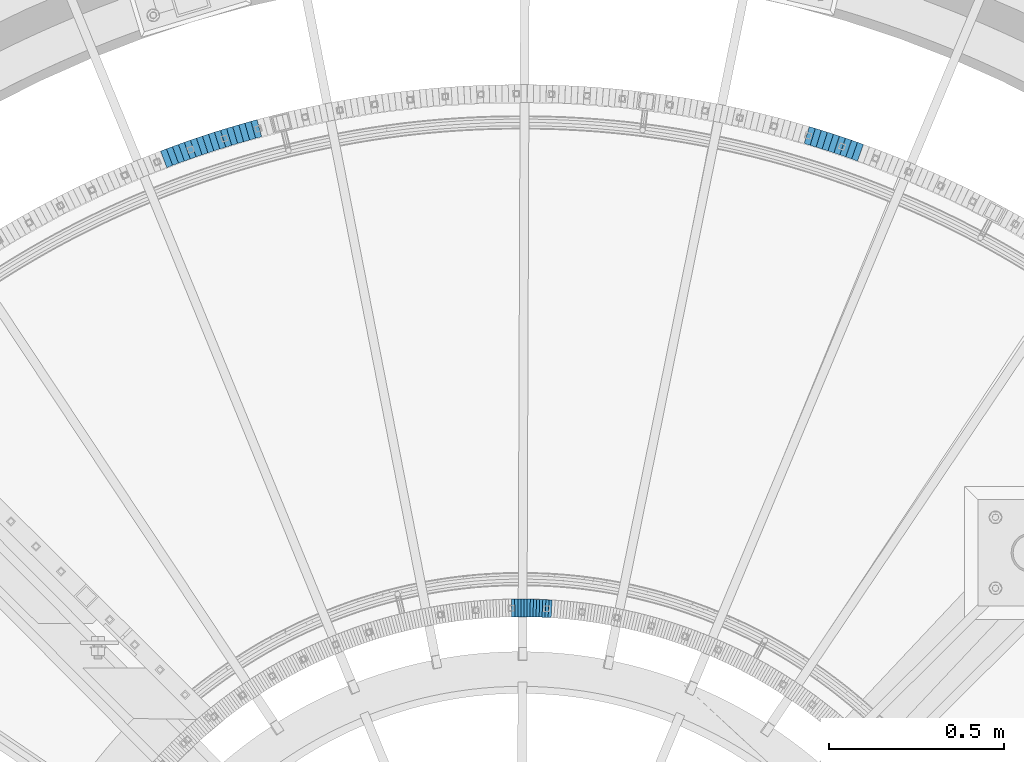
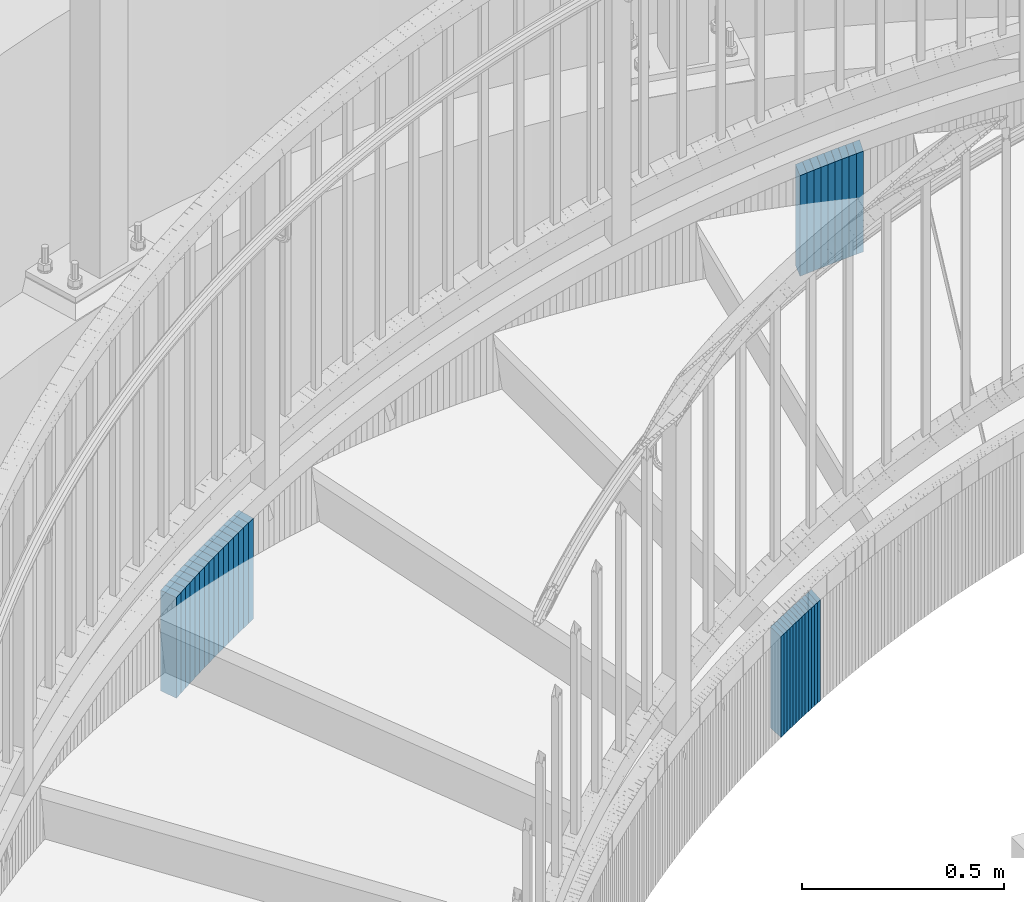
# One storey, part 902 of 975: 38 plates.
"""IFC2X3 building model written with IfcOpenShell, lengths in millimetres."""

from ifc_helpers import new_model, si_unit, frame, origin_with_axes, place, context, subcontext, project, spatial, faceted_brep, material, type_object, element, save


model = new_model("IFC2X3")

# Units and contexts
model_context = context("Model", 3, precision=1e-05, world=origin_with_axes())
body_context = subcontext(model_context, "Body", "Model", "MODEL_VIEW")
ifc_project = project(units=[si_unit("LENGTHUNIT", "METRE", prefix="MILLI"), si_unit("AREAUNIT", "SQUARE_METRE"), si_unit("VOLUMEUNIT", "CUBIC_METRE"), si_unit("MASSUNIT", "GRAM", prefix="KILO"), si_unit("TIMEUNIT", "SECOND"), si_unit("PLANEANGLEUNIT", "RADIAN"), si_unit("SOLIDANGLEUNIT", "STERADIAN"), si_unit("THERMODYNAMICTEMPERATUREUNIT", "DEGREE_CELSIUS"), si_unit("LUMINOUSINTENSITYUNIT", "LUMEN")], contexts=[model_context])

# Site, building, storey
site_placement = place(None, origin_with_axes())
site = spatial("IfcSite", under=ifc_project, at=site_placement, CompositionType="ELEMENT")
building_placement = place(site_placement, origin_with_axes())
building = spatial("IfcBuilding", under=site, at=building_placement, Name="Undefined", CompositionType="ELEMENT")
storey_placement = place(building_placement, origin_with_axes())
storey = spatial("IfcBuildingStorey", under=building, at=storey_placement, Name="Undefined", CompositionType="ELEMENT", Elevation=0.0)

# Plates
ifc_material = material(Name="STEEL/A36")
plate_type_1 = type_object("IfcPlateType", PredefinedType="NOTDEFINED")
plate_1_placement = place(storey_placement, frame((35690.0951937879, 6110.51674939472, 1376.49999999174), z_axis=(0.942371042718134, -0.334569600899929, 0.0), x_axis=(0.0, 0.0, -1.0)))
element("IfcPlate", 1, at=plate_1_placement, inside=storey, type_object=plate_type_1, material=ifc_material, Name="WALL", context=body_context, shape_type="Brep", body=[
    faceted_brep([(0.0, -25.3999999999724, -1.81898940354586e-11), (-5.69999980926514, -25.3999999999942, 17.9287471771386), (-5.69999980926514, 25.3999999999796, 17.9287471770876), (0.0, 25.3999999999869, 1.45519152283669e-11), (299.100006103516, -25.3999999999942, 17.9287471771386), (299.100006103516, 25.3999999999796, 17.9287471770876), (304.799987792969, -25.3999999999724, -1.81898940354586e-11), (304.799987792969, 25.3999999999869, 1.45519152283669e-11)], [[[0, 1, 2, 3]], [[1, 4, 5, 2]], [[4, 6, 7, 5]], [[6, 0, 3, 7]], [[5, 7, 3, 2]], [[6, 4, 1, 0]]]),
])
plate_2_placement = place(storey_placement, frame((35673.340070412, 6116.50076946703, 1370.69999999174), z_axis=(0.941741911475464, -0.336336397332401, 3.18269030685769e-10), x_axis=(0.0, 0.0, -1.0)))
element("IfcPlate", 2, at=plate_2_placement, inside=storey, type_object=plate_type_1, material=ifc_material, Name="WALL", context=body_context, shape_type="Brep", body=[
    faceted_brep([(0.0, -25.3999999999724, -1.81898940354586e-11), (-5.80000019073486, -25.3999999999578, 17.8370399475461), (-5.80000019073486, 25.4000000000524, 17.8370399475607), (0.0, 25.3999999999869, 1.45519152283669e-11), (299.0, -25.3999999999578, 17.8370399475461), (299.0, 25.4000000000524, 17.8370399475607), (304.799987792969, -25.3999999999724, -1.81898940354586e-11), (304.799987792969, 25.3999999999869, 1.45519152283669e-11)], [[[0, 1, 2, 3]], [[1, 4, 5, 2]], [[4, 6, 7, 5]], [[6, 0, 3, 7]], [[5, 7, 3, 2]], [[6, 4, 1, 0]]]),
])
plate_3_placement = place(storey_placement, frame((35656.1422322019, 6122.40505867621, 1364.99999999174), z_axis=(0.945847786021473, -0.324610483007371, 0.0), x_axis=(0.0, 0.0, -1.0)))
element("IfcPlate", 3, at=plate_3_placement, inside=storey, type_object=plate_type_1, material=ifc_material, Name="WALL", context=body_context, shape_type="Brep", body=[
    faceted_brep([(0.0, -25.3999999999724, -1.81898940354586e-11), (-5.69999980926514, -25.4000000000524, 17.8734436034756), (-5.69999980926514, 25.4000000000888, 17.8734436035884), (0.0, 25.3999999999869, 1.45519152283669e-11), (299.100006103516, -25.4000000000524, 17.8734436034756), (299.100006103516, 25.4000000000888, 17.8734436035884), (304.799987792969, -25.3999999999724, -1.81898940354586e-11), (304.799987792969, 25.3999999999869, 1.45519152283669e-11)], [[[0, 1, 2, 3]], [[1, 4, 5, 2]], [[4, 6, 7, 5]], [[6, 0, 3, 7]], [[5, 7, 3, 2]], [[6, 4, 1, 0]]]),
])
plate_4_placement = place(storey_placement, frame((35638.9717969497, 6128.16287711789, 1359.29999999174), z_axis=(0.948124102702791, -0.317900433900346, 0.0), x_axis=(0.0, 0.0, -1.0)))
element("IfcPlate", 4, at=plate_4_placement, inside=storey, type_object=plate_type_1, material=ifc_material, Name="WALL", context=body_context, shape_type="Brep", body=[
    faceted_brep([(0.0, -25.3999999999724, -1.81898940354586e-11), (-5.69999980926514, -25.3999999999942, 17.9287471771386), (-5.69999980926514, 25.3999999999796, 17.9287471770876), (0.0, 25.3999999999869, 1.45519152283669e-11), (299.100006103516, -25.3999999999942, 17.9287471771386), (299.100006103516, 25.3999999999796, 17.9287471770876), (304.799987792969, -25.3999999999724, -1.81898940354586e-11), (304.799987792969, 25.3999999999869, 1.45519152283669e-11)], [[[0, 1, 2, 3]], [[1, 4, 5, 2]], [[4, 6, 7, 5]], [[6, 0, 3, 7]], [[5, 7, 3, 2]], [[6, 4, 1, 0]]]),
])
plate_5_placement = place(storey_placement, frame((35621.857606345, 6133.73363749591, 1353.49999999174), z_axis=(0.950909944301323, -0.309467733098063, 0.0), x_axis=(0.0, 0.0, -1.0)))
element("IfcPlate", 5, at=plate_5_placement, inside=storey, type_object=plate_type_1, material=ifc_material, Name="WALL", context=body_context, shape_type="Brep", body=[
    faceted_brep([(0.0, -25.3999999999724, -1.81898940354586e-11), (-5.80000019073486, -25.400000000016, 17.7730140686072), (-5.80000019073486, 25.4000000000742, 17.7730140686326), (0.0, 25.3999999999869, 1.45519152283669e-11), (299.0, -25.400000000016, 17.7730140686072), (299.0, 25.4000000000742, 17.7730140686326), (304.799987792969, -25.3999999999724, -1.81898940354586e-11), (304.799987792969, 25.3999999999869, 1.45519152283669e-11)], [[[0, 1, 2, 3]], [[1, 4, 5, 2]], [[4, 6, 7, 5]], [[6, 0, 3, 7]], [[5, 7, 3, 2]], [[6, 4, 1, 0]]]),
])
plate_6_placement = place(storey_placement, frame((35604.8157611553, 6139.24721568696, 1347.79999999174), z_axis=(0.951444518718076, -0.30782028490879, 0.0), x_axis=(0.0, 0.0, -1.0)))
element("IfcPlate", 6, at=plate_6_placement, inside=storey, type_object=plate_type_1, material=ifc_material, Name="WALL", context=body_context, shape_type="Brep", body=[
    faceted_brep([(0.0, -25.3999999999724, -1.81898940354586e-11), (-5.69999980926514, -25.4000000000524, 17.8734436034756), (-5.69999980926514, 25.4000000000888, 17.8734436035884), (0.0, 25.3999999999869, 1.45519152283669e-11), (299.100006103516, -25.4000000000524, 17.8734436034756), (299.100006103516, 25.4000000000888, 17.8734436035884), (304.799987792969, -25.3999999999724, -1.81898940354586e-11), (304.799987792969, 25.3999999999869, 1.45519152283669e-11)], [[[0, 1, 2, 3]], [[1, 4, 5, 2]], [[4, 6, 7, 5]], [[6, 0, 3, 7]], [[5, 7, 3, 2]], [[6, 4, 1, 0]]]),
])
plate_7_placement = place(storey_placement, frame((35587.5458626546, 6144.70152460575, 1342.09999999174), z_axis=(0.953582665103915, -0.301131368032814, 0.0), x_axis=(0.0, 0.0, -1.0)))
element("IfcPlate", 7, at=plate_7_placement, inside=storey, type_object=plate_type_1, material=ifc_material, Name="WALL", context=body_context, shape_type="Brep", body=[
    faceted_brep([(0.0, -25.3999999999724, -1.81898940354586e-11), (-5.69999980926514, -25.3999999999942, 17.9287471771386), (-5.69999980926514, 25.3999999999796, 17.9287471770876), (0.0, 25.3999999999869, 1.45519152283669e-11), (299.100006103516, -25.3999999999942, 17.9287471771386), (299.100006103516, 25.3999999999796, 17.9287471770876), (304.799987792969, -25.3999999999724, -1.81898940354586e-11), (304.799987792969, 25.3999999999869, 1.45519152283669e-11)], [[[0, 1, 2, 3]], [[1, 4, 5, 2]], [[4, 6, 7, 5]], [[6, 0, 3, 7]], [[5, 7, 3, 2]], [[6, 4, 1, 0]]]),
])
plate_8_placement = place(storey_placement, frame((35570.3267361922, 6149.96963545787, 1336.39999999174), z_axis=(0.956264194651992, -0.292504341893548, 0.0), x_axis=(0.0, 0.0, -1.0)))
element("IfcPlate", 8, at=plate_8_placement, inside=storey, type_object=plate_type_1, material=ifc_material, Name="WALL", context=body_context, shape_type="Brep", body=[
    faceted_brep([(0.0, -25.3999999999724, -1.81898940354586e-11), (-5.69999980926514, -25.4000000000015, 17.7775135040429), (-5.69999980926514, 25.4000000000251, 17.7775135040793), (0.0, 25.3999999999869, 1.45519152283669e-11), (299.100006103516, -25.4000000000015, 17.7775135040429), (299.100006103516, 25.4000000000251, 17.7775135040793), (304.799987792969, -25.3999999999724, -1.81898940354586e-11), (304.799987792969, 25.3999999999869, 1.45519152283669e-11)], [[[0, 1, 2, 3]], [[1, 4, 5, 2]], [[4, 6, 7, 5]], [[6, 0, 3, 7]], [[5, 7, 3, 2]], [[6, 4, 1, 0]]]),
])
plate_9_placement = place(storey_placement, frame((35553.1869757374, 6155.18176190574, 1330.59999999174), z_axis=(0.956741613892852, -0.290938969967417, 0.0), x_axis=(0.0, 0.0, -1.0)))
element("IfcPlate", 9, at=plate_9_placement, inside=storey, type_object=plate_type_1, material=ifc_material, Name="WALL", context=body_context, shape_type="Brep", body=[
    faceted_brep([(0.0, -25.3999999999724, -1.81898940354586e-11), (-5.80000019073486, -25.4000000000524, 17.8675689696865), (-5.80000019073486, 25.4000000000888, 17.867568969803), (0.0, 25.3999999999869, 1.45519152283669e-11), (299.0, -25.4000000000524, 17.8675689696865), (299.0, 25.4000000000888, 17.867568969803), (304.799987792969, -25.3999999999724, -1.81898940354586e-11), (304.799987792969, 25.3999999999869, 1.45519152283669e-11)], [[[0, 1, 2, 3]], [[1, 4, 5, 2]], [[4, 6, 7, 5]], [[6, 0, 3, 7]], [[5, 7, 3, 2]], [[6, 4, 1, 0]]]),
])
plate_10_placement = place(storey_placement, frame((33968.0018909956, 6170.18223563984, 820.099999991737), z_axis=(0.96463428122535, 0.263591926061578, 0.0), x_axis=(0.0, 0.0, -1.0)))
element("IfcPlate", 10, at=plate_10_placement, inside=storey, type_object=plate_type_1, material=ifc_material, Name="WALL", context=body_context, shape_type="Brep", body=[
    faceted_brep([(0.0, -25.3999999999724, -1.81898940354586e-11), (-5.80000019073486, -25.4000000000078, 17.8305912018768), (-5.80000019073486, 25.4000000000042, 17.8305912017677), (0.0, 25.3999999999869, 1.45519152283669e-11), (299.0, -25.4000000000078, 17.8305912018768), (299.0, 25.4000000000042, 17.8305912017677), (304.799987792969, -25.3999999999724, -1.81898940354586e-11), (304.799987792969, 25.3999999999869, 1.45519152283669e-11)], [[[0, 1, 2, 3]], [[1, 4, 5, 2]], [[4, 6, 7, 5]], [[6, 0, 3, 7]], [[5, 7, 3, 2]], [[6, 4, 1, 0]]]),
])
for number, where, z_axis, x_axis, name in (
    (11, (33950.537969163, 6165.20858534691, 814.399999991737), (0.961734663398033, 0.273982549113392, 0.0), (0.0, 0.0, -1.0), "WALL"),
    (12, (33933.337969156, 6160.30858534617, 808.699999991737), (0.961734663398033, 0.273982549113392, 0.0), (0.0, 0.0, -1.0), "WALL"),
):
    element("IfcPlate", number, at=place(storey_placement, frame(where, z_axis=z_axis, x_axis=x_axis)), inside=storey, type_object=plate_type_1, material=ifc_material, Name=name, context=body_context, shape_type="Brep", body=[
        faceted_brep([(0.0, -25.3999999999724, -1.81898940354586e-11), (-5.69999980926514, -25.4000000000233, 17.8807163238162), (-5.69999980926514, 25.400000000096, 17.8807163239253), (0.0, 25.3999999999869, 1.45519152283669e-11), (299.100006103516, -25.4000000000233, 17.8807163238162), (299.100006103516, 25.400000000096, 17.8807163239253), (304.799987792969, -25.3999999999724, -1.81898940354586e-11), (304.799987792969, 25.3999999999869, 1.45519152283669e-11)], [[[0, 1, 2, 3]], [[1, 4, 5, 2]], [[4, 6, 7, 5]], [[6, 0, 3, 7]], [[5, 7, 3, 2]], [[6, 4, 1, 0]]]),
    ])
plate_11_placement = place(storey_placement, frame((33916.0687036398, 6155.25972906624, 802.999999991737), z_axis=(0.95981118781202, 0.280646545945036, 0.0), x_axis=(0.0, 0.0, -1.0)))
element("IfcPlate", 13, at=plate_11_placement, inside=storey, type_object=plate_type_1, material=ifc_material, Name="WALL", context=body_context, shape_type="Brep", body=[
    faceted_brep([(0.0, -25.3999999999724, -1.81898940354586e-11), (-5.69999980926514, -25.4000000000669, 17.8227386474155), (-5.69999980926514, 25.3999999999724, 17.8227386474609), (0.0, 25.3999999999869, 1.45519152283669e-11), (299.100006103516, -25.4000000000669, 17.8227386474155), (299.100006103516, 25.3999999999724, 17.8227386474609), (304.799987792969, -25.3999999999724, -1.81898940354586e-11), (304.799987792969, 25.3999999999869, 1.45519152283669e-11)], [[[0, 1, 2, 3]], [[1, 4, 5, 2]], [[4, 6, 7, 5]], [[6, 0, 3, 7]], [[5, 7, 3, 2]], [[6, 4, 1, 0]]]),
])
plate_12_placement = place(storey_placement, frame((33898.7072760665, 6149.98176188795, 797.199999991737), z_axis=(0.956741613892852, 0.290938969967417, 0.0), x_axis=(0.0, 0.0, -1.0)))
element("IfcPlate", 14, at=plate_12_placement, inside=storey, type_object=plate_type_1, material=ifc_material, Name="WALL", context=body_context, shape_type="Brep", body=[
    faceted_brep([(0.0, -25.3999999999724, -1.81898940354586e-11), (-5.80000019073486, -25.4000000000524, 17.8675689696865), (-5.80000019073486, 25.4000000000888, 17.867568969803), (0.0, 25.3999999999869, 1.45519152283669e-11), (299.0, -25.4000000000524, 17.8675689696865), (299.0, 25.4000000000888, 17.867568969803), (304.799987792969, -25.3999999999724, -1.81898940354586e-11), (304.799987792969, 25.3999999999869, 1.45519152283669e-11)], [[[0, 1, 2, 3]], [[1, 4, 5, 2]], [[4, 6, 7, 5]], [[6, 0, 3, 7]], [[5, 7, 3, 2]], [[6, 4, 1, 0]]]),
])
plate_13_placement = place(storey_placement, frame((33881.6072760635, 6144.7817618891, 791.499999991737), z_axis=(0.956741613892852, 0.290938969967417, 0.0), x_axis=(0.0, 0.0, -1.0)))
element("IfcPlate", 15, at=plate_13_placement, inside=storey, type_object=plate_type_1, material=ifc_material, Name="WALL", context=body_context, shape_type="Brep", body=[
    faceted_brep([(0.0, -25.3999999999724, -1.81898940354586e-11), (-5.69999980926514, -25.4000000000524, 17.8734436034756), (-5.69999980926514, 25.4000000000888, 17.8734436035884), (0.0, 25.3999999999869, 1.45519152283669e-11), (299.100006103516, -25.4000000000524, 17.8734436034756), (299.100006103516, 25.4000000000888, 17.8734436035884), (304.799987792969, -25.3999999999724, -1.81898940354586e-11), (304.799987792969, 25.3999999999869, 1.45519152283669e-11)], [[[0, 1, 2, 3]], [[1, 4, 5, 2]], [[4, 6, 7, 5]], [[6, 0, 3, 7]], [[5, 7, 3, 2]], [[6, 4, 1, 0]]]),
])
plate_14_placement = place(storey_placement, frame((33864.3075092682, 6139.28857719629, 785.799999991737), z_axis=(0.953072925427516, 0.302740811284235, 5.18711658514804e-10), x_axis=(0.0, 0.0, -1.0)))
element("IfcPlate", 16, at=plate_14_placement, inside=storey, type_object=plate_type_1, material=ifc_material, Name="WALL", context=body_context, shape_type="Brep", body=[
    faceted_brep([(0.0, -25.3999999999724, -1.81898940354586e-11), (-5.69999980926514, -25.3999999999614, 17.8370399475461), (-5.69999980926514, 25.4000000000487, 17.8370399475571), (0.0, 25.3999999999869, 1.45519152283669e-11), (299.100006103516, -25.3999999999614, 17.8370399475461), (299.100006103516, 25.4000000000487, 17.8370399475571), (304.799987792969, -25.3999999999724, -1.81898940354586e-11), (304.799987792969, 25.3999999999869, 1.45519152283669e-11)], [[[0, 1, 2, 3]], [[1, 4, 5, 2]], [[4, 6, 7, 5]], [[6, 0, 3, 7]], [[5, 7, 3, 2]], [[6, 4, 1, 0]]]),
])
plate_15_placement = place(storey_placement, frame((33847.1784906658, 6133.74721567303, 780.099999991737), z_axis=(0.951444518718076, 0.30782028490879, 0.0), x_axis=(0.0, 0.0, -1.0)))
element("IfcPlate", 17, at=plate_15_placement, inside=storey, type_object=plate_type_1, material=ifc_material, Name="WALL", context=body_context, shape_type="Brep", body=[
    faceted_brep([(0.0, -25.3999999999724, -1.81898940354586e-11), (-5.69999980926514, -25.4000000000524, 17.8734436034756), (-5.69999980926514, 25.4000000000888, 17.8734436035884), (0.0, 25.3999999999869, 1.45519152283669e-11), (299.100006103516, -25.4000000000524, 17.8734436034756), (299.100006103516, 25.4000000000888, 17.8734436035884), (304.799987792969, -25.3999999999724, -1.81898940354586e-11), (304.799987792969, 25.3999999999869, 1.45519152283669e-11)], [[[0, 1, 2, 3]], [[1, 4, 5, 2]], [[4, 6, 7, 5]], [[6, 0, 3, 7]], [[5, 7, 3, 2]], [[6, 4, 1, 0]]]),
])
plate_16_placement = place(storey_placement, frame((33830.1784906737, 6128.24721567412, 774.299999991737), z_axis=(0.951444518718076, 0.30782028490879, 0.0), x_axis=(0.0, 0.0, -1.0)))
element("IfcPlate", 18, at=plate_16_placement, inside=storey, type_object=plate_type_1, material=ifc_material, Name="WALL", context=body_context, shape_type="Brep", body=[
    faceted_brep([(0.0, -25.3999999999724, -1.81898940354586e-11), (-5.80000019073486, -25.4000000000524, 17.8675689696865), (-5.80000019073486, 25.4000000000888, 17.867568969803), (0.0, 25.3999999999869, 1.45519152283669e-11), (299.0, -25.4000000000524, 17.8675689696865), (299.0, 25.4000000000888, 17.867568969803), (304.799987792969, -25.3999999999724, -1.81898940354586e-11), (304.799987792969, 25.3999999999869, 1.45519152283669e-11)], [[[0, 1, 2, 3]], [[1, 4, 5, 2]], [[4, 6, 7, 5]], [[6, 0, 3, 7]], [[5, 7, 3, 2]], [[6, 4, 1, 0]]]),
])
plate_17_placement = place(storey_placement, frame((33812.9795429034, 6122.44844641515, 768.599999991737), z_axis=(0.947555965244538, 0.319589882082478, 0.0), x_axis=(0.0, 0.0, -1.0)))
element("IfcPlate", 19, at=plate_17_placement, inside=storey, type_object=plate_type_1, material=ifc_material, Name="WALL", context=body_context, shape_type="Brep", body=[
    faceted_brep([(0.0, -25.3999999999724, -1.81898940354586e-11), (-5.69999980926514, -25.3999999999614, 17.8370399475461), (-5.69999980926514, 25.4000000000487, 17.8370399475571), (0.0, 25.3999999999869, 1.45519152283669e-11), (299.100006103516, -25.3999999999614, 17.8370399475461), (299.100006103516, 25.4000000000487, 17.8370399475571), (304.799987792969, -25.3999999999724, -1.81898940354586e-11), (304.799987792969, 25.3999999999869, 1.45519152283669e-11)], [[[0, 1, 2, 3]], [[1, 4, 5, 2]], [[4, 6, 7, 5]], [[6, 0, 3, 7]], [[5, 7, 3, 2]], [[6, 4, 1, 0]]]),
])
plate_18_placement = place(storey_placement, frame((33795.9520196408, 6116.60505866201, 762.899999991737), z_axis=(0.945847786021473, 0.324610483007371, 0.0), x_axis=(0.0, 0.0, -1.0)))
element("IfcPlate", 20, at=plate_18_placement, inside=storey, type_object=plate_type_1, material=ifc_material, Name="WALL", context=body_context, shape_type="Brep", body=[
    faceted_brep([(0.0, -25.3999999999724, -1.81898940354586e-11), (-5.69999980926514, -25.4000000000524, 17.8734436034756), (-5.69999980926514, 25.4000000000888, 17.8734436035884), (0.0, 25.3999999999869, 1.45519152283669e-11), (299.100006103516, -25.4000000000524, 17.8734436034756), (299.100006103516, 25.4000000000888, 17.8734436035884), (304.799987792969, -25.3999999999724, -1.81898940354586e-11), (304.799987792969, 25.3999999999869, 1.45519152283669e-11)], [[[0, 1, 2, 3]], [[1, 4, 5, 2]], [[4, 6, 7, 5]], [[6, 0, 3, 7]], [[5, 7, 3, 2]], [[6, 4, 1, 0]]]),
])
plate_19_placement = place(storey_placement, frame((33778.7990580419, 6110.51674938196, 757.099999991737), z_axis=(0.942371042718134, 0.334569600899929, 0.0), x_axis=(0.0, 0.0, -1.0)))
element("IfcPlate", 21, at=plate_19_placement, inside=storey, type_object=plate_type_1, material=ifc_material, Name="WALL", context=body_context, shape_type="Brep", body=[
    faceted_brep([(0.0, -25.3999999999724, -1.81898940354586e-11), (-5.80000019073486, -25.3999999998778, 17.9254016876821), (-5.80000019073486, 25.3999999999651, 17.9254016876057), (0.0, 25.3999999999869, 1.45519152283669e-11), (299.0, -25.3999999998778, 17.9254016876821), (299.0, 25.3999999999651, 17.9254016876057), (304.799987792969, -25.3999999999724, -1.81898940354586e-11), (304.799987792969, 25.3999999999869, 1.45519152283669e-11)], [[[0, 1, 2, 3]], [[1, 4, 5, 2]], [[4, 6, 7, 5]], [[6, 0, 3, 7]], [[5, 7, 3, 2]], [[6, 4, 1, 0]]]),
])
plate_20_placement = place(storey_placement, frame((33761.9541814184, 6104.50076945173, 751.399999991737), z_axis=(0.941741911640086, 0.33633639687146, 0.0), x_axis=(0.0, 0.0, -1.0)))
element("IfcPlate", 22, at=plate_20_placement, inside=storey, type_object=plate_type_1, material=ifc_material, Name="WALL", context=body_context, shape_type="Brep", body=[
    faceted_brep([(0.0, -25.3999999999724, -1.81898940354586e-11), (-5.69999980926514, -25.3999999999614, 17.8370399475461), (-5.69999980926514, 25.4000000000487, 17.8370399475571), (0.0, 25.3999999999869, 1.45519152283669e-11), (299.100006103516, -25.3999999999614, 17.8370399475461), (299.100006103516, 25.4000000000487, 17.8370399475571), (304.799987792969, -25.3999999999724, -1.81898940354586e-11), (304.799987792969, 25.3999999999869, 1.45519152283669e-11)], [[[0, 1, 2, 3]], [[1, 4, 5, 2]], [[4, 6, 7, 5]], [[6, 0, 3, 7]], [[5, 7, 3, 2]], [[6, 4, 1, 0]]]),
])
plate_21_placement = place(storey_placement, frame((33745.0282635786, 6098.35542439524, 745.699999991737), z_axis=(0.939956673199756, 0.341293792072531, 0.0), x_axis=(0.0, 0.0, -1.0)))
element("IfcPlate", 23, at=plate_21_placement, inside=storey, type_object=plate_type_1, material=ifc_material, Name="WALL", context=body_context, shape_type="Brep", body=[
    faceted_brep([(0.0, -25.3999999999724, -1.81898940354586e-11), (-5.69999980926514, -25.4000000000524, 17.8734436034756), (-5.69999980926514, 25.4000000000888, 17.8734436035884), (0.0, 25.3999999999869, 1.45519152283669e-11), (299.100006103516, -25.4000000000524, 17.8734436034756), (299.100006103516, 25.4000000000888, 17.8734436035884), (304.799987792969, -25.3999999999724, -1.81898940354586e-11), (304.799987792969, 25.3999999999869, 1.45519152283669e-11)], [[[0, 1, 2, 3]], [[1, 4, 5, 2]], [[4, 6, 7, 5]], [[6, 0, 3, 7]], [[5, 7, 3, 2]], [[6, 4, 1, 0]]]),
])
plate_22_placement = place(storey_placement, frame((33727.9785904629, 6091.96328600092, 739.899999991737), z_axis=(0.936329177363565, 0.351123442136337, 0.0), x_axis=(0.0, 0.0, -1.0)))
element("IfcPlate", 24, at=plate_22_placement, inside=storey, type_object=plate_type_1, material=ifc_material, Name="WALL", context=body_context, shape_type="Brep", body=[
    faceted_brep([(0.0, -25.3999999999724, -1.81898940354586e-11), (-5.80000019073486, -25.3999999999869, 17.9387855530222), (-5.80000019073486, 25.3999999999469, 17.9387855528548), (0.0, 25.3999999999869, 1.45519152283669e-11), (299.0, -25.3999999999869, 17.9387855530222), (299.0, 25.3999999999469, 17.9387855528548), (304.799987792969, -25.3999999999724, -1.81898940354586e-11), (304.799987792969, 25.3999999999869, 1.45519152283669e-11)], [[[0, 1, 2, 3]], [[1, 4, 5, 2]], [[4, 6, 7, 5]], [[6, 0, 3, 7]], [[5, 7, 3, 2]], [[6, 4, 1, 0]]]),
])
plate_23_placement = place(storey_placement, frame((33711.2318220561, 6085.64569535684, 734.199999991737), z_axis=(0.93563663233069, 0.352964718124752, 0.0), x_axis=(0.0, 0.0, -1.0)))
element("IfcPlate", 25, at=plate_23_placement, inside=storey, type_object=plate_type_1, material=ifc_material, Name="WALL", context=body_context, shape_type="Brep", body=[
    faceted_brep([(0.0, -25.3999999999724, -1.81898940354586e-11), (-5.69999980926514, -25.3999999999578, 17.853290557905), (-5.69999980926514, 25.4000000000124, 17.8532905578759), (0.0, 25.3999999999869, 1.45519152283669e-11), (299.100006103516, -25.3999999999578, 17.853290557905), (299.100006103516, 25.4000000000124, 17.8532905578759), (304.799987792969, -25.3999999999724, -1.81898940354586e-11), (304.799987792969, 25.3999999999869, 1.45519152283669e-11)], [[[0, 1, 2, 3]], [[1, 4, 5, 2]], [[4, 6, 7, 5]], [[6, 0, 3, 7]], [[5, 7, 3, 2]], [[6, 4, 1, 0]]]),
])
plate_type_2 = type_object("IfcPlateType", PredefinedType="NOTDEFINED")
plate_24_placement = place(storey_placement, frame((34813.5508422423, 4798.49754171914, 1118.50000000056), z_axis=(0.99842564215979, -0.0560913280089772, 0.0), x_axis=(0.0, 0.0, -1.0)))
element("IfcPlate", 26, at=plate_24_placement, inside=storey, type_object=plate_type_2, material=ifc_material, Name="WALL", context=body_context, shape_type="Brep", body=[
    faceted_brep([(0.0, -25.3999999999724, -1.81898940354586e-11), (-5.69999980926514, -25.400000000096, 8.9140338897214), (-5.69999980926514, 25.4000000000524, 8.91403388979779), (0.0, 25.3999999999869, 1.45519152283669e-11), (299.100006103516, -25.400000000096, 8.9140338897214), (299.100006103516, 25.4000000000524, 8.91403388979779), (304.799987792969, -25.3999999999724, -1.81898940354586e-11), (304.799987792969, 25.3999999999869, 1.45519152283669e-11)], [[[0, 1, 2, 3]], [[1, 4, 5, 2]], [[4, 6, 7, 5]], [[6, 0, 3, 7]], [[5, 7, 3, 2]], [[6, 4, 1, 0]]]),
])
plate_25_placement = place(storey_placement, frame((34804.6508422459, 4798.99754171936, 1112.70000000056), z_axis=(0.99842564215979, -0.0560913280089772, 0.0), x_axis=(0.0, 0.0, -1.0)))
element("IfcPlate", 27, at=plate_25_placement, inside=storey, type_object=plate_type_2, material=ifc_material, Name="WALL", context=body_context, shape_type="Brep", body=[
    faceted_brep([(0.0, -25.3999999999724, -1.81898940354586e-11), (-5.80000019073486, -25.399999999976, 8.91066741944087), (-5.80000019073486, 25.4000000000051, 8.91066741945178), (0.0, 25.3999999999869, 1.45519152283669e-11), (299.0, -25.399999999976, 8.91066741944087), (299.0, 25.4000000000051, 8.91066741945178), (304.799987792969, -25.3999999999724, -1.81898940354586e-11), (304.799987792969, 25.3999999999869, 1.45519152283669e-11)], [[[0, 1, 2, 3]], [[1, 4, 5, 2]], [[4, 6, 7, 5]], [[6, 0, 3, 7]], [[5, 7, 3, 2]], [[6, 4, 1, 0]]]),
])
plate_26_placement = place(storey_placement, frame((34795.9477863791, 4799.38260234633, 1107.00000000056), z_axis=(0.999013806448466, -0.0444006140199318, 0.0), x_axis=(0.0, 0.0, -1.0)))
element("IfcPlate", 28, at=plate_26_placement, inside=storey, type_object=plate_type_2, material=ifc_material, Name="WALL", context=body_context, shape_type="Brep", body=[
    faceted_brep([(0.0, -25.3999999999724, -1.81898940354586e-11), (-5.69999980926514, -25.4000000000087, 9.01387786864507), (-5.69999980926514, 25.4000000000124, 9.0138778686669), (0.0, 25.3999999999869, 1.45519152283669e-11), (299.100006103516, -25.4000000000087, 9.01387786864507), (299.100006103516, 25.4000000000124, 9.0138778686669), (304.799987792969, -25.3999999999724, -1.81898940354586e-11), (304.799987792969, 25.3999999999869, 1.45519152283669e-11)], [[[0, 1, 2, 3]], [[1, 4, 5, 2]], [[4, 6, 7, 5]], [[6, 0, 3, 7]], [[5, 7, 3, 2]], [[6, 4, 1, 0]]]),
])
plate_27_placement = place(storey_placement, frame((34787.3198681804, 4799.67197074189, 1101.30000000056), z_axis=(0.999432373568723, -0.0336887319854623, 0.0), x_axis=(0.0, 0.0, -1.0)))
element("IfcPlate", 29, at=plate_27_placement, inside=storey, type_object=plate_type_2, material=ifc_material, Name="WALL", context=body_context, shape_type="Brep", body=[
    faceted_brep([(0.0, -25.3999999999724, -1.81898940354586e-11), (-5.69999980926514, -25.400000000096, 8.9140338897214), (-5.69999980926514, 25.4000000000524, 8.91403388979779), (0.0, 25.3999999999869, 1.45519152283669e-11), (299.100006103516, -25.400000000096, 8.9140338897214), (299.100006103516, 25.4000000000524, 8.91403388979779), (304.799987792969, -25.3999999999724, -1.81898940354586e-11), (304.799987792969, 25.3999999999869, 1.45519152283669e-11)], [[[0, 1, 2, 3]], [[1, 4, 5, 2]], [[4, 6, 7, 5]], [[6, 0, 3, 7]], [[5, 7, 3, 2]], [[6, 4, 1, 0]]]),
])
plate_28_placement = place(storey_placement, frame((34778.4198681781, 4799.97197074231, 1095.50000000055), z_axis=(0.999432373568723, -0.0336887319854623, 0.0), x_axis=(0.0, 0.0, -1.0)))
element("IfcPlate", 30, at=plate_28_placement, inside=storey, type_object=plate_type_2, material=ifc_material, Name="WALL", context=body_context, shape_type="Brep", body=[
    faceted_brep([(0.0, -25.3999999999724, -1.81898940354586e-11), (-5.80000019073486, -25.399999999976, 8.91066741944087), (-5.80000019073486, 25.4000000000051, 8.91066741945178), (0.0, 25.3999999999869, 1.45519152283669e-11), (299.0, -25.399999999976, 8.91066741944087), (299.0, 25.4000000000051, 8.91066741945178), (304.799987792969, -25.3999999999724, -1.81898940354586e-11), (304.799987792969, 25.3999999999869, 1.45519152283669e-11)], [[[0, 1, 2, 3]], [[1, 4, 5, 2]], [[4, 6, 7, 5]], [[6, 0, 3, 7]], [[5, 7, 3, 2]], [[6, 4, 1, 0]]]),
])
plate_29_placement = place(storey_placement, frame((34769.4293652851, 4800.27165239325, 1089.80000000055), z_axis=(0.999444906986924, -0.0333148299995647, 0.0), x_axis=(0.0, 0.0, -1.0)))
element("IfcPlate", 31, at=plate_29_placement, inside=storey, type_object=plate_type_2, material=ifc_material, Name="WALL", context=body_context, shape_type="Brep", body=[
    faceted_brep([(0.0, -25.3999999999724, -1.81898940354586e-11), (-5.69999980926514, -25.3999999999724, 9.00000000009459), (-5.69999980926514, 25.3999999999905, 8.99999999997453), (0.0, 25.3999999999869, 1.45519152283669e-11), (299.100006103516, -25.3999999999724, 9.00000000009459), (299.100006103516, 25.3999999999905, 8.99999999997453), (304.799987792969, -25.3999999999724, -1.81898940354586e-11), (304.799987792969, 25.3999999999869, 1.45519152283669e-11)], [[[0, 1, 2, 3]], [[1, 4, 5, 2]], [[4, 6, 7, 5]], [[6, 0, 3, 7]], [[5, 7, 3, 2]], [[6, 4, 1, 0]]]),
])
plate_30_placement = place(storey_placement, frame((34760.8049195176, 4800.46396393415, 1084.00000000055), z_axis=(0.999747602222632, -0.0224662380050031, 0.0), x_axis=(0.0, 0.0, -1.0)))
element("IfcPlate", 32, at=plate_30_placement, inside=storey, type_object=plate_type_2, material=ifc_material, Name="WALL", context=body_context, shape_type="Brep", body=[
    faceted_brep([(0.0, -25.3999999999724, -1.81898940354586e-11), (-5.80000019073486, -25.4000000000024, 8.90224647521973), (-5.80000019073486, 25.3999999999996, 8.90224647527066), (0.0, 25.3999999999869, 1.45519152283669e-11), (299.0, -25.4000000000024, 8.90224647521973), (299.0, 25.3999999999996, 8.90224647527066), (304.799987792969, -25.3999999999724, -1.81898940354586e-11), (304.799987792969, 25.3999999999869, 1.45519152283669e-11)], [[[0, 1, 2, 3]], [[1, 4, 5, 2]], [[4, 6, 7, 5]], [[6, 0, 3, 7]], [[5, 7, 3, 2]], [[6, 4, 1, 0]]]),
])
plate_31_placement = place(storey_placement, frame((34752.0933571612, 4800.55912078649, 1078.30000000055), z_axis=(0.999938277323275, -0.0111104250035915, 0.0), x_axis=(0.0, 0.0, -1.0)))
element("IfcPlate", 33, at=plate_31_placement, inside=storey, type_object=plate_type_2, material=ifc_material, Name="WALL", context=body_context, shape_type="Brep", body=[
    faceted_brep([(0.0, -25.3999999999724, -1.81898940354586e-11), (-5.69999980926514, -25.3999999999724, 9.00000000009459), (-5.69999980926514, 25.3999999999905, 8.99999999997453), (0.0, 25.3999999999869, 1.45519152283669e-11), (299.100006103516, -25.3999999999724, 9.00000000009459), (299.100006103516, 25.3999999999905, 8.99999999997453), (304.799987792969, -25.3999999999724, -1.81898940354586e-11), (304.799987792969, 25.3999999999869, 1.45519152283669e-11)], [[[0, 1, 2, 3]], [[1, 4, 5, 2]], [[4, 6, 7, 5]], [[6, 0, 3, 7]], [[5, 7, 3, 2]], [[6, 4, 1, 0]]]),
])
plate_32_placement = place(storey_placement, frame((34743.190186702, 4800.65915621124, 1072.50000000055), z_axis=(0.999936882631805, -0.0112352459958629, 0.0), x_axis=(0.0, 0.0, -1.0)))
element("IfcPlate", 34, at=plate_32_placement, inside=storey, type_object=plate_type_2, material=ifc_material, Name="WALL", context=body_context, shape_type="Brep", body=[
    faceted_brep([(0.0, -25.3999999999724, -1.81898940354586e-11), (-5.80000019073486, -25.4000000000024, 8.90224647521973), (-5.80000019073486, 25.3999999999996, 8.90224647527066), (0.0, 25.3999999999869, 1.45519152283669e-11), (299.0, -25.4000000000024, 8.90224647521973), (299.0, 25.3999999999996, 8.90224647527066), (304.799987792969, -25.3999999999724, -1.81898940354586e-11), (304.799987792969, 25.3999999999869, 1.45519152283669e-11)], [[[0, 1, 2, 3]], [[1, 4, 5, 2]], [[4, 6, 7, 5]], [[6, 0, 3, 7]], [[5, 7, 3, 2]], [[6, 4, 1, 0]]]),
])
for number, where, z_axis, x_axis, name in (
    (35, (34734.4755619503, 4800.65755302999, 1066.80000000055), (1.0, 0.0, 0.0), (0.0, 0.0, -1.0), "WALL"),
    (36, (34725.4755619503, 4800.65755302991, 1061.10000000055), (1.0, 0.0, 0.0), (0.0, 0.0, -1.0), "WALL"),
):
    element("IfcPlate", number, at=place(storey_placement, frame(where, z_axis=z_axis, x_axis=x_axis)), inside=storey, type_object=plate_type_2, material=ifc_material, Name=name, context=body_context, shape_type="Brep", body=[
        faceted_brep([(0.0, -25.3999999999724, -1.81898940354586e-11), (-5.69999980926514, -25.3999999999724, 9.00000000009459), (-5.69999980926514, 25.3999999999905, 8.99999999997453), (0.0, 25.3999999999869, 1.45519152283669e-11), (299.100006103516, -25.3999999999724, 9.00000000009459), (299.100006103516, 25.3999999999905, 8.99999999997453), (304.799987792969, -25.3999999999724, -1.81898940354586e-11), (304.799987792969, 25.3999999999869, 1.45519152283669e-11)], [[[0, 1, 2, 3]], [[1, 4, 5, 2]], [[4, 6, 7, 5]], [[6, 0, 3, 7]], [[5, 7, 3, 2]], [[6, 4, 1, 0]]]),
    ])
plate_33_placement = place(storey_placement, frame((34716.8609371952, 4800.55915621086, 1055.30000000055), z_axis=(0.999936882631805, 0.0112352459958629, 0.0), x_axis=(0.0, 0.0, -1.0)))
element("IfcPlate", 37, at=plate_33_placement, inside=storey, type_object=plate_type_2, material=ifc_material, Name="WALL", context=body_context, shape_type="Brep", body=[
    faceted_brep([(0.0, -25.3999999999724, -1.81898940354586e-11), (-5.80000019073486, -25.4000000000024, 8.90224647521973), (-5.80000019073486, 25.3999999999996, 8.90224647527066), (0.0, 25.3999999999869, 1.45519152283669e-11), (299.0, -25.4000000000024, 8.90224647521973), (299.0, 25.3999999999996, 8.90224647527066), (304.799987792969, -25.3999999999724, -1.81898940354586e-11), (304.799987792969, 25.3999999999869, 1.45519152283669e-11)], [[[0, 1, 2, 3]], [[1, 4, 5, 2]], [[4, 6, 7, 5]], [[6, 0, 3, 7]], [[5, 7, 3, 2]], [[6, 4, 1, 0]]]),
])
plate_34_placement = place(storey_placement, frame((34707.8577667339, 4800.45912078548, 1049.60000000055), z_axis=(0.999938277323275, 0.0111104250035915, 0.0), x_axis=(0.0, 0.0, -1.0)))
element("IfcPlate", 38, at=plate_34_placement, inside=storey, type_object=plate_type_2, material=ifc_material, Name="WALL", context=body_context, shape_type="Brep", body=[
    faceted_brep([(0.0, -25.3999999999724, -1.81898940354586e-11), (-5.69999980926514, -25.3999999999724, 9.00000000009459), (-5.69999980926514, 25.3999999999905, 8.99999999997453), (0.0, 25.3999999999869, 1.45519152283669e-11), (299.100006103516, -25.3999999999724, 9.00000000009459), (299.100006103516, 25.3999999999905, 8.99999999997453), (304.799987792969, -25.3999999999724, -1.81898940354586e-11), (304.799987792969, 25.3999999999869, 1.45519152283669e-11)], [[[0, 1, 2, 3]], [[1, 4, 5, 2]], [[4, 6, 7, 5]], [[6, 0, 3, 7]], [[5, 7, 3, 2]], [[6, 4, 1, 0]]]),
])

save(model, "model.ifc")
